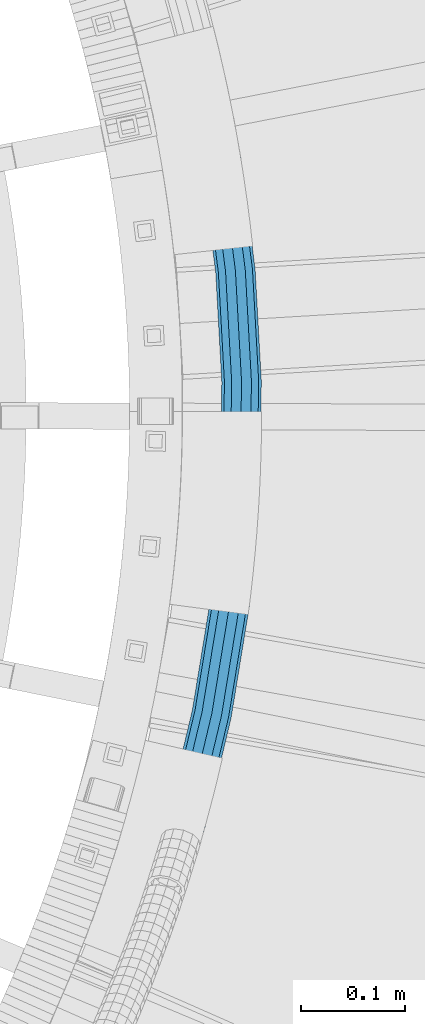
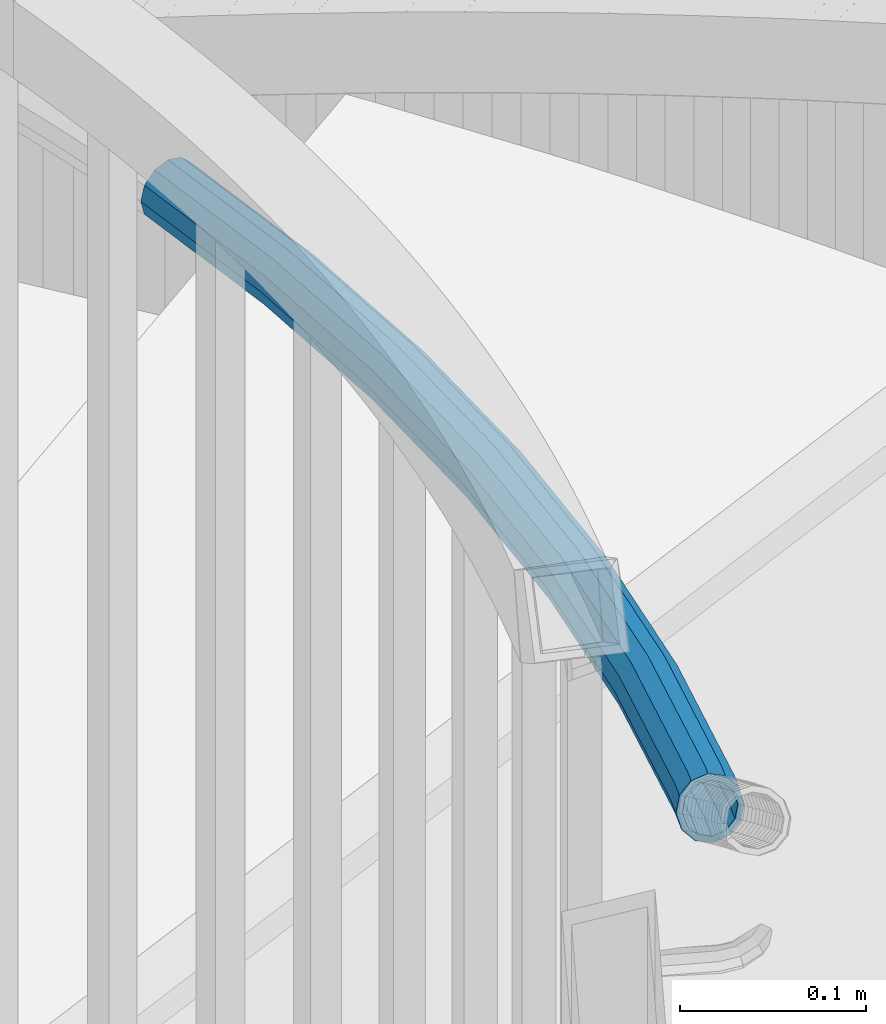
# One storey, part 498 of 975: 1 beam.
"""IFC2X3 building model written with IfcOpenShell, lengths in millimetres."""

import ifcopenshell
import ifcopenshell.guid

model = None  # the IFC model being written
_history = None  # IfcOwnerHistory: only IFC2X3 demands one
_inside = {}  # id of a spatial element -> (the spatial element, [elements in it])
_under = {}  # id of a project, library or spatial element -> (it, [spatial elements below it])
_declared = {}  # id of a project -> (the project, [libraries it declares])
_typed = {}  # id of a type object -> (the type object, [elements of that type])
_made_of = {}  # id of a material, layer set ... -> (it, [elements and type objects made of it])


def new_model(schema):
    """Start an empty IFC model of exactly this schema.

    Asked for "IFC4X3", IfcOpenShell would pick the latest addendum, in which some entities
    have other attributes; the version numbers below select the first issue.
    IFC2X3 requires an IfcOwnerHistory on every rooted entity: one is made here for all.
    """
    global model, _history
    if schema == "IFC4X3":
        model = ifcopenshell.file(schema_version=(4, 3, 0, 0))
    else:
        model = ifcopenshell.file(schema=schema)
    _inside.clear()
    _under.clear()
    _declared.clear()
    _typed.clear()
    _made_of.clear()
    _history = None
    if model.schema == "IFC2X3":
        org = make("IfcOrganization", Name="unknown")
        user = make(
            "IfcPersonAndOrganization",
            ThePerson=make("IfcPerson", FamilyName="unknown"),
            TheOrganization=org,
        )
        app = make(
            "IfcApplication",
            ApplicationDeveloper=org,
            Version="unknown",
            ApplicationFullName="unknown",
            ApplicationIdentifier="unknown",
        )
        _history = make(
            "IfcOwnerHistory",
            OwningUser=user,
            OwningApplication=app,
            ChangeAction="ADDED",
            CreationDate=0,
        )
    return model


def make(cls, **values):
    """One entity of the class cls with the attributes given. An attribute that is None is left unset."""
    return model.create_entity(
        cls, **{name: value for name, value in values.items() if value is not None}
    )


def rooted(cls, **values):
    """An entity with a GlobalId (a new one), such as an element, a storey or a relation."""
    return make(cls, GlobalId=ifcopenshell.guid.new(), OwnerHistory=_history, **values)


def si_unit(unit_type, name, prefix=None):
    """IfcSIUnit, for example si_unit("LENGTHUNIT", "METRE", prefix="MILLI")."""
    return make("IfcSIUnit", UnitType=unit_type, Prefix=prefix, Name=name)


def assignment(units):
    """IfcUnitAssignment: the units of a project."""
    return None if units is None else make("IfcUnitAssignment", Units=units)


def point(xyz):
    """IfcCartesianPoint."""
    return None if xyz is None else make("IfcCartesianPoint", Coordinates=xyz)


def direction(xyz):
    """IfcDirection."""
    return None if xyz is None else make("IfcDirection", DirectionRatios=xyz)


def frame(location, z_axis=None, x_axis=None):
    """IfcAxis2Placement3D, a coordinate frame: its origin and axes. An axis left out is left unset."""
    return make(
        "IfcAxis2Placement3D",
        Location=point(location),
        Axis=direction(z_axis),
        RefDirection=direction(x_axis),
    )


def origin_with_axes():
    """The frame at (0, 0, 0) with the z axis (0, 0, 1) and the x axis (1, 0, 0) written out."""
    return frame((0.0, 0.0, 0.0), z_axis=(0.0, 0.0, 1.0), x_axis=(1.0, 0.0, 0.0))


def place(relative_to, where):
    """IfcLocalPlacement: puts the frame where relative to a parent placement (None: the world)."""
    return make(
        "IfcLocalPlacement", PlacementRelTo=relative_to, RelativePlacement=where
    )


def context(
    kind, dimensions, precision=None, world=None, true_north=None, identifier=None
):
    """IfcGeometricRepresentationContext, for example the 3D "Model" context."""
    return make(
        "IfcGeometricRepresentationContext",
        ContextIdentifier=identifier,
        ContextType=kind,
        CoordinateSpaceDimension=dimensions,
        Precision=precision,
        WorldCoordinateSystem=world,
        TrueNorth=true_north,
    )


def subcontext(parent, identifier, kind, view, scale=None):
    """IfcGeometricRepresentationSubContext, for example "Body" below "Model"."""
    return make(
        "IfcGeometricRepresentationSubContext",
        ContextIdentifier=identifier,
        ContextType=kind,
        ParentContext=parent,
        TargetScale=scale,
        TargetView=view,
    )


def project(units=None, contexts=None):
    """IfcProject with its units and contexts."""
    return rooted(
        "IfcProject",
        Name="project",
        RepresentationContexts=contexts,
        UnitsInContext=assignment(units),
    )


def spatial(cls, under=None, at=None, **own):
    """A site, building, storey or space (cls), placed at a placement, below another one or the project."""
    s = rooted(cls, ObjectPlacement=at, **own)
    if under is not None:
        _under.setdefault(under.id(), (under, []))[1].append(s)
    return s


def faces_of(points, faces, orient=None, outer=None):
    """IfcFace entities. A face is a list of loops; a loop is a list of indices into points, from 0.

    orient and outer hold one flag for each loop. By default every Orientation is true, the
    first loop of a face is its IfcFaceOuterBound and the others are IfcFaceBound.
    """
    made = []
    for i, loops in enumerate(faces):
        bounds = []
        for j, loop in enumerate(loops):
            is_outer = j == 0 if outer is None else outer[i][j]
            bounds.append(
                make(
                    "IfcFaceOuterBound" if is_outer else "IfcFaceBound",
                    Bound=make("IfcPolyLoop", Polygon=[points[k] for k in loop]),
                    Orientation=True if orient is None else orient[i][j],
                )
            )
        made.append(make("IfcFace", Bounds=bounds))
    return made


def faceted_brep(points, faces, orient=None, outer=None, voids=None):
    """IfcFacetedBrep: a solid bounded by flat faces; with voids (closed shells), ...WithVoids."""
    shared = [point(p) for p in points]
    hull = make("IfcClosedShell", CfsFaces=faces_of(shared, faces, orient, outer))
    if voids is None:
        return make("IfcFacetedBrep", Outer=hull)
    return make(
        "IfcFacetedBrepWithVoids",
        Outer=hull,
        Voids=[
            make(cls, CfsFaces=faces_of(shared, fs, o, b)) for cls, fs, o, b in voids
        ],
    )


def shape(context_of_items, identifier, shape_type, items):
    """IfcShapeRepresentation: the items that make up one representation, for example the "Body"."""
    return make(
        "IfcShapeRepresentation",
        ContextOfItems=context_of_items,
        RepresentationIdentifier=identifier,
        RepresentationType=shape_type,
        Items=items,
    )


def material(Name=None, Category=None):
    """IfcMaterial."""
    return make("IfcMaterial", Name=Name, Category=Category)


def made_of(thing, what):
    """Note that an element or type object is made of a material, layer set ...; save() writes the relation."""
    if what is not None:
        _made_of.setdefault(what.id(), (what, []))[1].append(thing)
    return thing


def type_object(cls, material=None, **own):
    """A type object (cls), such as IfcWallType, which elements share."""
    return made_of(rooted(cls, **own), material)


def element(
    cls,
    number,
    at=None,
    inside=None,
    cuts=None,
    type_object=None,
    material=None,
    context=None,
    identifier="Body",
    shape_type=None,
    held_by="IfcProductDefinitionShape",
    body=None,
    shapes=None,
    **own,
):
    """One element of the class cls, such as IfcWall. Its Tag is "e" and its number.

    at: its placement. inside: the storey or other place that contains it. cuts: it is an
    opening in that element (IfcRelVoidsElement). A single representation is given by context,
    identifier, shape_type and body (its items); several are given by shapes. held_by: the class
    of the entity that holds the representations. save() writes the other relations.
    """
    e = rooted(cls, Tag="e%d" % number, ObjectPlacement=at, **own)
    if body is not None:
        shapes = [shape(context, identifier, shape_type, body)]
    if shapes is not None:
        e.Representation = make(held_by, Representations=shapes)
    if inside is not None:
        _inside.setdefault(inside.id(), (inside, []))[1].append(e)
    if cuts is not None:
        rooted(
            "IfcRelVoidsElement", RelatingBuildingElement=cuts, RelatedOpeningElement=e
        )
    if type_object is not None:
        _typed.setdefault(type_object.id(), (type_object, []))[1].append(e)
    return made_of(e, material)


def aggregate(whole, parts):
    """IfcRelAggregates: a whole, such as a stair, and the parts it consists of."""
    return rooted("IfcRelAggregates", RelatingObject=whole, RelatedObjects=parts)


def save(model, path):
    """Write the relations noted so far, then the file.

    IfcRelAggregates (storeys below a building ...), IfcRelContainedInSpatialStructure (elements
    in a storey), IfcRelDefinesByType, IfcRelAssociatesMaterial and IfcRelDeclares: one each for
    every whole, place, type object, material and project.
    """
    for whole, parts in _under.values():
        aggregate(whole, parts)
    for where, things in _inside.values():
        rooted(
            "IfcRelContainedInSpatialStructure",
            RelatedElements=things,
            RelatingStructure=where,
        )
    for kind, things in _typed.values():
        rooted("IfcRelDefinesByType", RelatedObjects=things, RelatingType=kind)
    for what, things in _made_of.values():
        rooted("IfcRelAssociatesMaterial", RelatedObjects=things, RelatingMaterial=what)
    for by, libraries in _declared.values():
        rooted("IfcRelDeclares", RelatingContext=by, RelatedDefinitions=libraries)
    model.write(path)


model = new_model("IFC2X3")

# Units and contexts
model_context = context("Model", 3, precision=1e-05, world=origin_with_axes())
body_context = subcontext(model_context, "Body", "Model", "MODEL_VIEW")
ifc_project = project(units=[si_unit("LENGTHUNIT", "METRE", prefix="MILLI"), si_unit("AREAUNIT", "SQUARE_METRE"), si_unit("VOLUMEUNIT", "CUBIC_METRE"), si_unit("MASSUNIT", "GRAM", prefix="KILO"), si_unit("TIMEUNIT", "SECOND"), si_unit("PLANEANGLEUNIT", "RADIAN"), si_unit("SOLIDANGLEUNIT", "STERADIAN"), si_unit("THERMODYNAMICTEMPERATUREUNIT", "DEGREE_CELSIUS"), si_unit("LUMINOUSINTENSITYUNIT", "LUMEN")], contexts=[model_context])

# Site, building, storey
site_placement = place(None, origin_with_axes())
site = spatial("IfcSite", under=ifc_project, at=site_placement, CompositionType="ELEMENT")
building_placement = place(site_placement, origin_with_axes())
building = spatial("IfcBuilding", under=site, at=building_placement, Name="Undefined", CompositionType="ELEMENT")
storey_placement = place(building_placement, origin_with_axes())
storey = spatial("IfcBuildingStorey", under=building, at=storey_placement, Name="Undefined", CompositionType="ELEMENT", Elevation=0.0)

# Beam
ifc_material = material()
beam_type = type_object("IfcBeamType", PredefinedType="NOTDEFINED")
beam_placement = place(storey_placement, frame((36194.1723970717, 3645.31205116334, 3028.95), z_axis=(0.0, 0.0, 1.0), x_axis=(-0.196926337030694, -0.980418287152822, 0.0)))
element("IfcBeam", 1, at=beam_placement, inside=storey, type_object=beam_type, material=ifc_material, Name="HANDRAIL", context=body_context, shape_type="Brep", body=[
    faceted_brep([(5.84764347187229, -15.4266633082516, -9.52500000000009), (3.37613853261064, -8.90658821371471, -16.4977839420935), (104.265940793066, 25.2108938102174, -16.4977839420935), (106.258894147748, 18.5289889299311, -9.52500000000009), (207.361129738389, 51.9342318528506, -16.4977839420935), (208.865070676286, 45.1255699021785, -9.52500000000009), (312.120568030778, 71.1231575257771, -16.4977839420935), (313.127602501703, 64.2234765565299, -9.52500000000009), (417.994382837878, 82.6769498908252, -16.4977839420935), (418.499225008829, 75.7224657053812, -9.52500000000009), (524.426852065648, 86.534964135084, -16.4977839420935), (524.426852065646, 79.5621801930029, -9.52500000000009), (630.859321293412, 82.6769498901776, -16.4977839420935), (630.354479122463, 75.7224657047409, -9.52500000000009), (524.426852065646, 96.0599641350855, -19.0500000000002), (631.54894852383, 92.1769519577065, -19.0500000000002), (417.304755607463, 92.1769519583395, -19.0500000000002), (310.744933361006, 80.5482970077865, -19.0500000000002), (205.30670821143, 61.2350370432323, -19.0500000000002), (101.543515882015, 34.338545622355, -19.0500000000002), (-3.63797880709171e-12, 3.63797880709171e-12, -19.0500000000002), (-3.37613853261064, 8.90658821372199, -16.4977839420935), (98.8210909709596, 43.4661974344999, -16.4977839420935), (203.252286684474, 70.5358422336285, -16.4977839420935), (309.369298691232, 89.9734364898031, -16.4977839420935), (416.615128377047, 101.676954025868, -16.4977839420935), (524.426852065648, 105.58496413508, -16.4977839420935), (632.238575754247, 101.676954025221, -16.4977839420935), (524.426852065648, 112.557748077161, -9.52500000000009), (632.743417925198, 108.631438210658, -9.52500000000009), (416.110286206098, 108.631438211312, -9.52500000000009), (308.362264220308, 96.873117459043, -9.52500000000009), (201.748345746577, 77.3445041842933, -9.52500000000009), (96.8281376162795, 50.1481023147862, -9.52500000000009), (-5.84764347187411, 15.4266633082589, -9.52500000000009), (-6.7522770652231, 17.8131764274367, 0.0), (96.0986660599083, 52.5938492466448, 0.0), (201.197865157515, 79.8366474240174, 0.0), (307.993664021462, 99.398575971798, 0.0), (415.92550114663, 111.176956093397, 0.0), (524.426852065648, 115.109964135074, 0.0), (632.928202984665, 111.176956092742, 0.0), (524.426852065648, 112.557748077161, 9.52500000000009), (632.743417925198, 108.631438210658, 9.52500000000009), (416.110286206098, 108.631438211312, 9.52500000000009), (308.362264220308, 96.873117459043, 9.52500000000009), (201.748345746577, 77.3445041842933, 9.52500000000009), (96.8281376162795, 50.1481023147862, 9.52500000000009), (-5.84764347187411, 15.4266633082589, 9.52500000000009), (-3.37613853261064, 8.90658821372199, 16.4977839420935), (98.8210909709596, 43.4661974344999, 16.4977839420935), (203.252286684474, 70.5358422336285, 16.4977839420935), (309.369298691232, 89.9734364898031, 16.4977839420935), (416.615128377047, 101.676954025868, 16.4977839420935), (524.426852065648, 105.58496413508, 16.4977839420935), (632.238575754247, 101.676954025221, 16.4977839420935), (524.426852065646, 96.0599641350855, 19.0500000000002), (631.54894852383, 92.1769519577065, 19.0500000000002), (417.304755607463, 92.1769519583395, 19.0500000000002), (310.744933361006, 80.5482970077865, 19.0500000000002), (205.30670821143, 61.2350370432323, 19.0500000000002), (101.543515882015, 34.338545622355, 19.0500000000002), (-3.63797880709171e-12, 3.63797880709171e-12, 19.0500000000002), (3.37613853261064, -8.90658821371471, 16.4977839420935), (104.265940793066, 25.2108938102174, 16.4977839420935), (207.361129738389, 51.9342318528506, 16.4977839420935), (312.120568030778, 71.1231575257771, 16.4977839420935), (417.994382837878, 82.6769498908252, 16.4977839420935), (524.426852065648, 86.534964135084, 16.4977839420935), (630.859321293412, 82.6769498901776, 16.4977839420935), (524.426852065646, 79.5621801930029, 9.52500000000009), (630.354479122463, 75.7224657047409, 9.52500000000009), (418.499225008829, 75.7224657053812, 9.52500000000009), (313.127602501703, 64.2234765565299, 9.52500000000009), (208.865070676286, 45.1255699021785, 9.52500000000009), (106.258894147748, 18.5289889299311, 9.52500000000009), (5.84764347187229, -15.4266633082516, 9.52500000000009), (6.75227706522128, -17.8131764274294, 0.0), (106.988365704119, 16.0832419980725, 0.0), (209.415551265347, 42.6334266624617, 0.0), (313.496202700548, 61.6980180437749, 0.0), (418.684010068297, 73.1769478232964, 0.0), (524.426852065646, 77.0099641350971, 0.0), (630.169694062994, 73.1769478226634, 0.0), (643.506579191304, 71.7215208895868, 0.0), (640.99827926871, 74.5609296148614, 9.52500000000009), (639.559337276676, 81.7275349812044, 16.4977839420935), (639.575316559924, 91.3010508681982, 19.0500000000002), (641.041935482412, 100.716261425216, 16.4977839420935), (643.566214688251, 107.450368586935, 9.52500000000009), (646.471775602769, 109.698973777624, 0.0), (648.980075525364, 106.859565052349, -9.52500000000009), (650.419017517397, 99.6929596860136, -16.4977839420935), (650.40303823415, 90.1194437990198, -19.0500000000002), (648.936419311663, 80.7042332419951, -16.4977839420935), (646.412140105822, 73.9701260802831, -9.52500000000009), (4.71709906730939, -12.4441750686528, -7.68350000000009), (2.72341841630623, -7.18464782572846, -13.3082123799554), (-3.63797880709171e-12, 3.63797880709171e-12, -15.3670000000002), (-2.72341841630623, 7.18464782573574, -13.3082123799554), (-4.71709906731121, 12.4441750686601, -7.68350000000009), (-5.44683683261246, 14.3692956514642, 0.0), (-4.71709906731121, 12.4441750686601, 7.68350000000009), (-2.72341841630623, 7.18464782573574, 13.3082123799554), (-3.63797880709171e-12, 3.63797880709171e-12, 15.3670000000002), (2.72341841630623, -7.18464782572846, 13.3082123799554), (4.71709906730939, -12.4441750686528, 7.68350000000009), (5.44683683261246, -14.3692956514642, 0.0), (103.739605310264, 26.9755731605619, 13.3082123799554), (105.347254349705, 21.5855032238032, 7.68350000000009), (105.935694738513, 19.6126006987761, 0.0), (105.347254349705, 21.5855032238032, -7.68350000000009), (103.739605310264, 26.9755731605619, -13.3082123799554), (101.543515882015, 34.338545622355, -15.3670000000002), (99.3474264537654, 41.7015180841554, -13.3082123799554), (97.739777414321, 47.0915880209213, -7.68350000000009), (97.1513370255143, 49.0644905459485, 0.0), (97.739777414321, 47.0915880209213, 7.68350000000009), (99.3474264537654, 41.7015180841554, 13.3082123799554), (101.543515882015, 34.338545622355, 15.3670000000002), (205.30670821143, 61.2350370432323, 15.3670000000002), (206.96394157651, 53.7323875229922, 13.3082123799554), (208.177120599747, 48.2400668827904, 7.68350000000009), (208.621174941591, 46.2297380027376, 0.0), (208.177120599747, 48.2400668827904, -7.68350000000009), (206.96394157651, 53.7323875229922, -13.3082123799554), (205.30670821143, 61.2350370432323, -15.3670000000002), (203.649474846352, 68.7376865634869, -13.3082123799554), (202.436295823116, 74.2300072036887, -7.68350000000009), (201.992241481272, 76.240336083727, 0.0), (202.436295823116, 74.2300072036887, 7.68350000000009), (203.649474846352, 68.7376865634869, 13.3082123799554), (309.635254727389, 88.1512428566057, 13.3082123799554), (310.744933361006, 80.5482970077865, 15.3670000000002), (311.85461199462, 72.9453511589672, 13.3082123799554), (312.666953134501, 67.3796085104404, 7.68350000000009), (312.964290628235, 65.3424053101553, 0.0), (312.666953134501, 67.3796085104404, -7.68350000000009), (311.85461199462, 72.9453511589672, -13.3082123799554), (310.744933361006, 80.5482970077865, -15.3670000000002), (309.635254727389, 88.1512428566057, -13.3082123799554), (308.82291358751, 93.7169855051325, -7.68350000000009), (308.525576093773, 95.7541887054249, 0.0), (308.82291358751, 93.7169855051325, 7.68350000000009), (416.341216957029, 105.450237535733, 7.68350000000009), (416.748456308262, 99.8402869594793, 13.3082123799554), (417.304755607463, 92.1769519583395, 15.3670000000002), (417.861054906665, 84.513616957207, 13.3082123799554), (418.268294257898, 78.9036663809529, 7.68350000000009), (418.417354205869, 76.8502819560672, 0.0), (418.268294257898, 78.9036663809529, -7.68350000000009), (417.861054906665, 84.513616957207, -13.3082123799554), (417.304755607463, 92.1769519583395, -15.3670000000002), (416.748456308262, 99.8402869594793, -13.3082123799554), (416.341216957029, 105.450237535733, -7.68350000000009), (416.192157009056, 107.503621960619, 0.0), (524.426852065648, 111.426964135069, 0.0), (524.426852065648, 109.368176515025, 7.68350000000009), (524.426852065648, 103.743464135077, 13.3082123799554), (524.426852065646, 96.0599641350855, 15.3670000000002), (524.426852065648, 88.3764641350863, 13.3082123799554), (524.426852065646, 82.7517517551387, 7.68350000000009), (524.426852065646, 80.6929641350944, 0.0), (524.426852065646, 82.7517517551387, -7.68350000000009), (524.426852065648, 88.3764641350863, -13.3082123799554), (524.426852065646, 96.0599641350855, -15.3670000000002), (524.426852065648, 103.743464135077, -13.3082123799554), (524.426852065648, 109.368176515025, -7.68350000000009), (632.512487174266, 105.450237535086, -7.68350000000009), (632.661547122239, 107.503621959964, 0.0), (632.512487174266, 105.450237535086, 7.68350000000009), (632.105247823034, 99.840286958839, 13.3082123799554), (631.54894852383, 92.1769519577065, 15.3670000000002), (630.992649224627, 84.5136169565667, 13.3082123799554), (630.585409873393, 78.9036663803272, 7.68350000000009), (630.436349925423, 76.8502819554342, 0.0), (630.585409873393, 78.9036663803272, -7.68350000000009), (630.992649224627, 84.5136169565667, -13.3082123799554), (631.54894852383, 92.1769519577065, -15.3670000000002), (632.105247823034, 99.840286958839, -13.3082123799554), (649.36924842746, 97.9563019645502, -13.3082123799554), (648.20850188722, 103.737363626722, -7.68350000000009), (646.185139949661, 106.027819998446, 0.0), (643.841320811949, 104.213945144627, 7.68350000000009), (641.805068919239, 98.7817653675011, 13.3082123799554), (640.621996321766, 91.1868288515034, 15.3670000000002), (640.609106366614, 83.4641927026605, 13.3082123799554), (641.769852906853, 77.6831310404887, 7.68350000000009), (643.793214844412, 75.3926746687648, 0.0), (646.137033982122, 77.2065495225906, -7.68350000000009), (648.173285874835, 82.6387292997097, -13.3082123799554), (649.356358472309, 90.2336658157001, -15.3670000000002)], [[[0, 1, 2, 3]], [[3, 2, 4, 5]], [[5, 4, 6, 7]], [[7, 6, 8, 9]], [[9, 8, 10, 11]], [[11, 10, 12, 13]], [[10, 14, 15, 12]], [[8, 16, 14, 10]], [[6, 17, 16, 8]], [[4, 18, 17, 6]], [[2, 19, 18, 4]], [[1, 20, 19, 2]], [[20, 21, 22, 19]], [[19, 22, 23, 18]], [[18, 23, 24, 17]], [[17, 24, 25, 16]], [[16, 25, 26, 14]], [[14, 26, 27, 15]], [[26, 28, 29, 27]], [[25, 30, 28, 26]], [[24, 31, 30, 25]], [[23, 32, 31, 24]], [[22, 33, 32, 23]], [[21, 34, 33, 22]], [[34, 35, 36, 33]], [[33, 36, 37, 32]], [[32, 37, 38, 31]], [[31, 38, 39, 30]], [[30, 39, 40, 28]], [[28, 40, 41, 29]], [[40, 42, 43, 41]], [[39, 44, 42, 40]], [[38, 45, 44, 39]], [[37, 46, 45, 38]], [[36, 47, 46, 37]], [[35, 48, 47, 36]], [[48, 49, 50, 47]], [[47, 50, 51, 46]], [[46, 51, 52, 45]], [[45, 52, 53, 44]], [[44, 53, 54, 42]], [[42, 54, 55, 43]], [[54, 56, 57, 55]], [[53, 58, 56, 54]], [[52, 59, 58, 53]], [[51, 60, 59, 52]], [[50, 61, 60, 51]], [[49, 62, 61, 50]], [[62, 63, 64, 61]], [[61, 64, 65, 60]], [[60, 65, 66, 59]], [[59, 66, 67, 58]], [[58, 67, 68, 56]], [[56, 68, 69, 57]], [[68, 70, 71, 69]], [[67, 72, 70, 68]], [[66, 73, 72, 67]], [[65, 74, 73, 66]], [[64, 75, 74, 65]], [[63, 76, 75, 64]], [[76, 77, 78, 75]], [[75, 78, 79, 74]], [[74, 79, 80, 73]], [[73, 80, 81, 72]], [[72, 81, 82, 70]], [[70, 82, 83, 71]], [[71, 83, 84, 85]], [[69, 71, 85, 86]], [[57, 69, 86, 87]], [[55, 57, 87, 88]], [[43, 55, 88, 89]], [[41, 43, 89, 90]], [[29, 41, 90, 91]], [[27, 29, 91, 92]], [[15, 27, 92, 93]], [[12, 15, 93, 94]], [[13, 12, 94, 95]], [[83, 13, 95, 84]], [[82, 11, 13, 83]], [[81, 9, 11, 82]], [[80, 7, 9, 81]], [[79, 5, 7, 80]], [[78, 3, 5, 79]], [[77, 0, 3, 78]], [[76, 63, 62, 49, 48, 35, 34, 21, 20, 1, 0, 77], [96, 97, 98, 99, 100, 101, 102, 103, 104, 105, 106, 107]], [[106, 105, 108, 109]], [[107, 106, 109, 110]], [[96, 107, 110, 111]], [[97, 96, 111, 112]], [[98, 97, 112, 113]], [[99, 98, 113, 114]], [[100, 99, 114, 115]], [[101, 100, 115, 116]], [[102, 101, 116, 117]], [[103, 102, 117, 118]], [[104, 103, 118, 119]], [[105, 104, 119, 108]], [[108, 119, 120, 121]], [[109, 108, 121, 122]], [[110, 109, 122, 123]], [[111, 110, 123, 124]], [[112, 111, 124, 125]], [[113, 112, 125, 126]], [[114, 113, 126, 127]], [[115, 114, 127, 128]], [[116, 115, 128, 129]], [[117, 116, 129, 130]], [[118, 117, 130, 131]], [[119, 118, 131, 120]], [[120, 131, 132, 133]], [[121, 120, 133, 134]], [[122, 121, 134, 135]], [[123, 122, 135, 136]], [[124, 123, 136, 137]], [[125, 124, 137, 138]], [[126, 125, 138, 139]], [[127, 126, 139, 140]], [[128, 127, 140, 141]], [[129, 128, 141, 142]], [[130, 129, 142, 143]], [[131, 130, 143, 132]], [[132, 143, 144, 145]], [[133, 132, 145, 146]], [[134, 133, 146, 147]], [[135, 134, 147, 148]], [[136, 135, 148, 149]], [[137, 136, 149, 150]], [[138, 137, 150, 151]], [[139, 138, 151, 152]], [[140, 139, 152, 153]], [[141, 140, 153, 154]], [[142, 141, 154, 155]], [[143, 142, 155, 144]], [[144, 155, 156, 157]], [[145, 144, 157, 158]], [[146, 145, 158, 159]], [[147, 146, 159, 160]], [[148, 147, 160, 161]], [[149, 148, 161, 162]], [[150, 149, 162, 163]], [[151, 150, 163, 164]], [[152, 151, 164, 165]], [[153, 152, 165, 166]], [[154, 153, 166, 167]], [[155, 154, 167, 156]], [[156, 167, 168, 169]], [[157, 156, 169, 170]], [[158, 157, 170, 171]], [[159, 158, 171, 172]], [[160, 159, 172, 173]], [[161, 160, 173, 174]], [[162, 161, 174, 175]], [[163, 162, 175, 176]], [[164, 163, 176, 177]], [[165, 164, 177, 178]], [[166, 165, 178, 179]], [[167, 166, 179, 168]], [[168, 179, 180, 181]], [[169, 168, 181, 182]], [[170, 169, 182, 183]], [[171, 170, 183, 184]], [[172, 171, 184, 185]], [[173, 172, 185, 186]], [[174, 173, 186, 187]], [[175, 174, 187, 188]], [[176, 175, 188, 189]], [[177, 176, 189, 190]], [[178, 177, 190, 191]], [[179, 178, 191, 180]], [[90, 89, 88, 87, 86, 85, 84, 95, 94, 93, 92, 91], [190, 189, 188, 187, 186, 185, 184, 183, 182, 181, 180, 191]]]),
])

save(model, "model.ifc")
